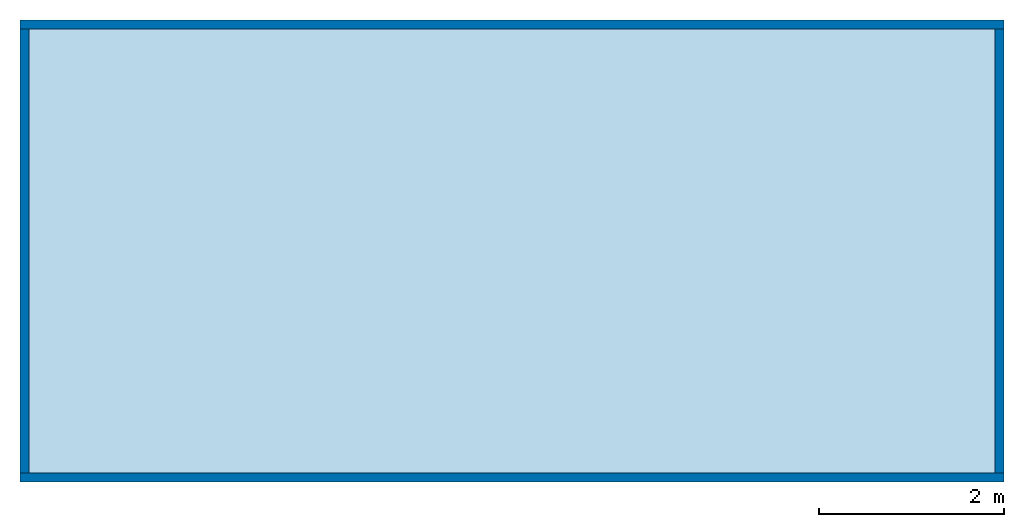
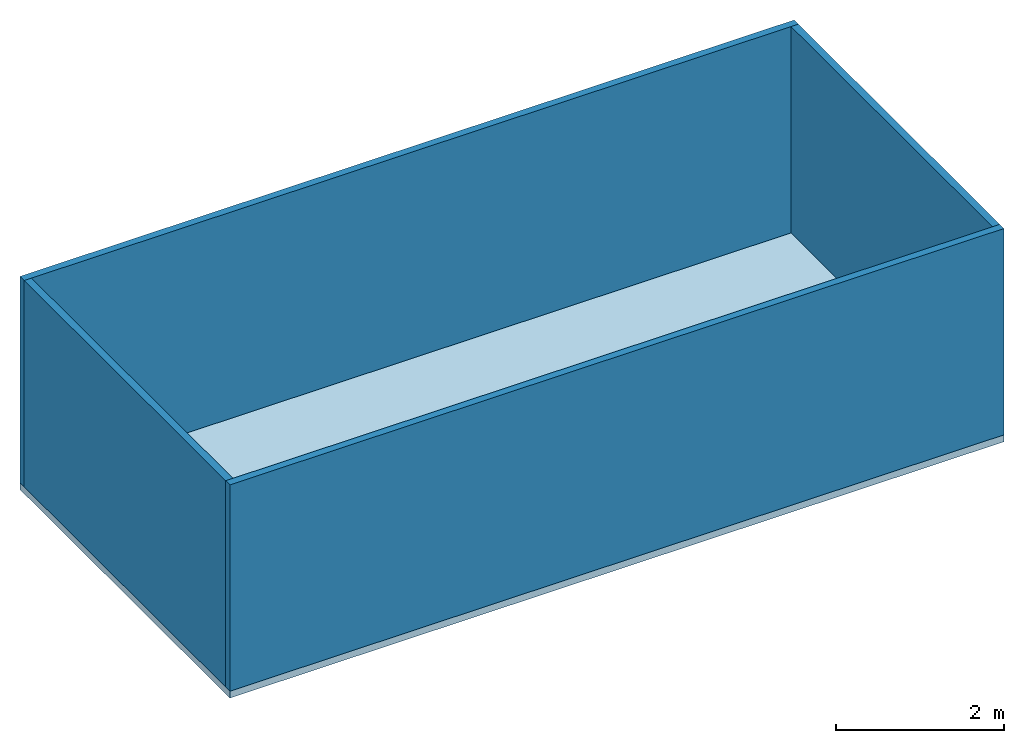
# One storey: 4 walls, 1 slab.
"""IFC4 building model written with IfcOpenShell, lengths in metres."""

from ifc_helpers import new_model, entity, si_unit, converted_unit, frame, origin_with_axes, origin_2d_with_axis, place, context, subcontext, project, spatial, line, indexed_curve, outline, extrude, material, layer, layer_set, layer_usage, type_object, element, save


model = new_model("IFC4")

# Units and contexts
model_context = context("Model", 3, precision=1e-05, world=origin_with_axes())
plan_context = context("Plan", 2, precision=1e-05, world=origin_2d_with_axis())
body_context = subcontext(model_context, "Body", "Model", "MODEL_VIEW")
ifc_project = project(units=[si_unit("VOLUMEUNIT", "CUBIC_METRE"), si_unit("LENGTHUNIT", "METRE"), converted_unit("PLANEANGLEUNIT", "degree", entity("IfcReal", 0.0174532925199433), si_unit("PLANEANGLEUNIT", "RADIAN"), dimensions=[0, 0, 0, 0, 0, 0, 0]), si_unit("AREAUNIT", "SQUARE_METRE")], contexts=[model_context, plan_context])

# Site, building, storey
site_placement = place(None, origin_with_axes())
site = spatial("IfcSite", under=ifc_project, at=site_placement)
building_placement = place(site_placement, origin_with_axes())
building = spatial("IfcBuilding", under=site, at=building_placement, Name="Building1")
storey_placement = place(building_placement, origin_with_axes())
storey = spatial("IfcBuildingStorey", under=building, at=storey_placement, Name="Storey")

# Slab
ifc_material = material()
ifc_layer_1 = layer(ifc_material, 0.1)
ifc_layer_set_1 = layer_set([ifc_layer_1])
ifc_layer_usage_1 = layer_usage(ifc_layer_set_1, "AXIS3", "POSITIVE", 0.0)
slab_type = type_object("IfcSlabType", Name="SLB-01", PredefinedType="FLOOR", material=ifc_layer_set_1)
slab_placement = place(storey_placement, frame((-15.0317516326904, -24.820463180542, -0.100000001490116), z_axis=(0.0, 0.0, 1.0), x_axis=(1.0, 0.0, 0.0)))
element("IfcSlab", 1, at=slab_placement, inside=storey, type_object=slab_type, material=ifc_layer_usage_1, Name="Slab", context=body_context, shape_type="SweptSolid", body=[
    extrude(outline(indexed_curve([(0.0, 0.0), (10.64599609375, 0.0), (10.64599609375, 5.0), (0.0, 5.0)], segments=[line(3, 2), line(2, 1), line(1, 4), line(4, 3)], self_intersect=False)), None, (0.0, 0.0, 1.0), 0.1),
])

# Walls
ifc_layer_2 = layer(ifc_material, 0.1)
ifc_layer_set_2 = layer_set([ifc_layer_2])
ifc_layer_usage_2 = layer_usage(ifc_layer_set_2, "AXIS2", "POSITIVE", 0.0)
wall_type = type_object("IfcWallType", Name="WAL-01", PredefinedType="SOLIDWALL", material=ifc_layer_set_2)
wall_1_placement = place(storey_placement, frame((-4.38575553894043, -19.820463180542, 0.0), z_axis=(0.0, 0.0, 1.0), x_axis=(-0.999999999999989, 1.50995802528085e-07, 0.0)))
element("IfcWall", 2, at=wall_1_placement, inside=storey, type_object=wall_type, material=ifc_layer_usage_2, Name="Wall", context=body_context, shape_type="SweptSolid", body=[
    extrude(outline(indexed_curve([(0.0, 0.0), (0.0, 0.1), (10.645996172133, 0.1), (10.645996172133, 0.0), (0.0, 0.0)], self_intersect=False)), origin_with_axes(), (0.0, 0.0, 1.0), 3.0),
])
ifc_layer_usage_3 = layer_usage(ifc_layer_set_2, "AXIS2", "POSITIVE", 0.0)
wall_2_placement = place(storey_placement, frame((-4.38575553894043, -24.7204627990723, 0.0), z_axis=(0.0, 0.0, 1.0), x_axis=(-0.999999999999989, 1.50995802528085e-07, 0.0)))
element("IfcWall", 3, at=wall_2_placement, inside=storey, type_object=wall_type, material=ifc_layer_usage_3, Name="Wall", context=body_context, shape_type="SweptSolid", body=[
    extrude(outline(indexed_curve([(0.0, 0.0), (0.0, 0.1), (10.645996172133, 0.1), (10.645996172133, 0.0), (0.0, 0.0)], self_intersect=False)), origin_with_axes(), (0.0, 0.0, 1.0), 3.0),
])
ifc_layer_usage_4 = layer_usage(ifc_layer_set_2, "AXIS2", "POSITIVE", 0.0)
wall_3_placement = place(storey_placement, frame((-4.38575839996338, -24.7204627990723, 0.0), z_axis=(0.0, 0.0, 1.0), x_axis=(3.13916473260163e-07, 0.999999999999951, 0.0)))
element("IfcWall", 4, at=wall_3_placement, inside=storey, type_object=wall_type, material=ifc_layer_usage_4, Name="Wall", context=body_context, shape_type="SweptSolid", body=[
    extrude(outline(indexed_curve([(0.0, 0.0), (0.0, 0.1), (4.799999300639, 0.1), (4.799999300639, 0.0), (0.0, 0.0)], self_intersect=False)), origin_with_axes(), (0.0, 0.0, 1.0), 3.0),
])
ifc_layer_usage_5 = layer_usage(ifc_layer_set_2, "AXIS2", "POSITIVE", 0.0)
wall_4_placement = place(storey_placement, frame((-14.9317531585693, -24.7204627990723, 0.0), z_axis=(0.0, 0.0, 1.0), x_axis=(3.13916473260163e-07, 0.999999999999951, 0.0)))
element("IfcWall", 5, at=wall_4_placement, inside=storey, type_object=wall_type, material=ifc_layer_usage_5, Name="Wall", context=body_context, shape_type="SweptSolid", body=[
    extrude(outline(indexed_curve([(0.0, 0.0), (0.0, 0.1), (4.799999300639, 0.1), (4.799999300639, 0.0), (0.0, 0.0)], self_intersect=False)), origin_with_axes(), (0.0, 0.0, 1.0), 3.0),
])

save(model, "model.ifc")
